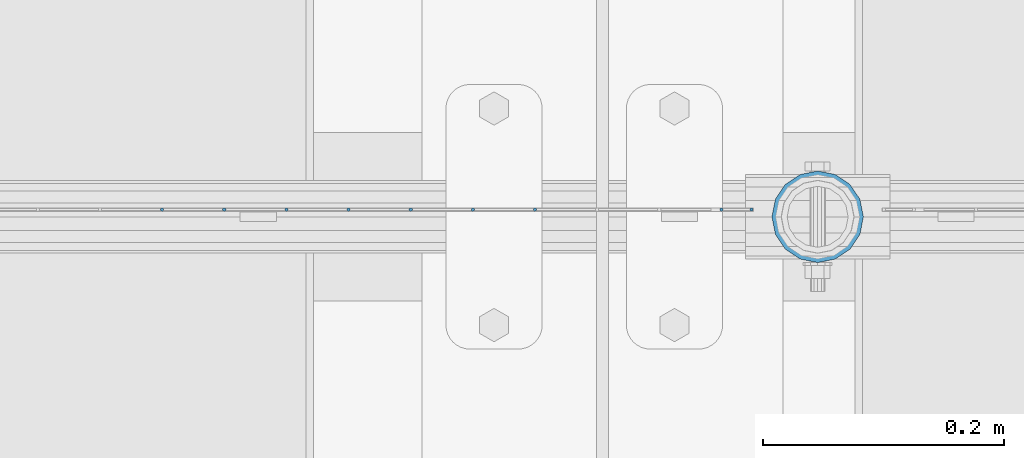
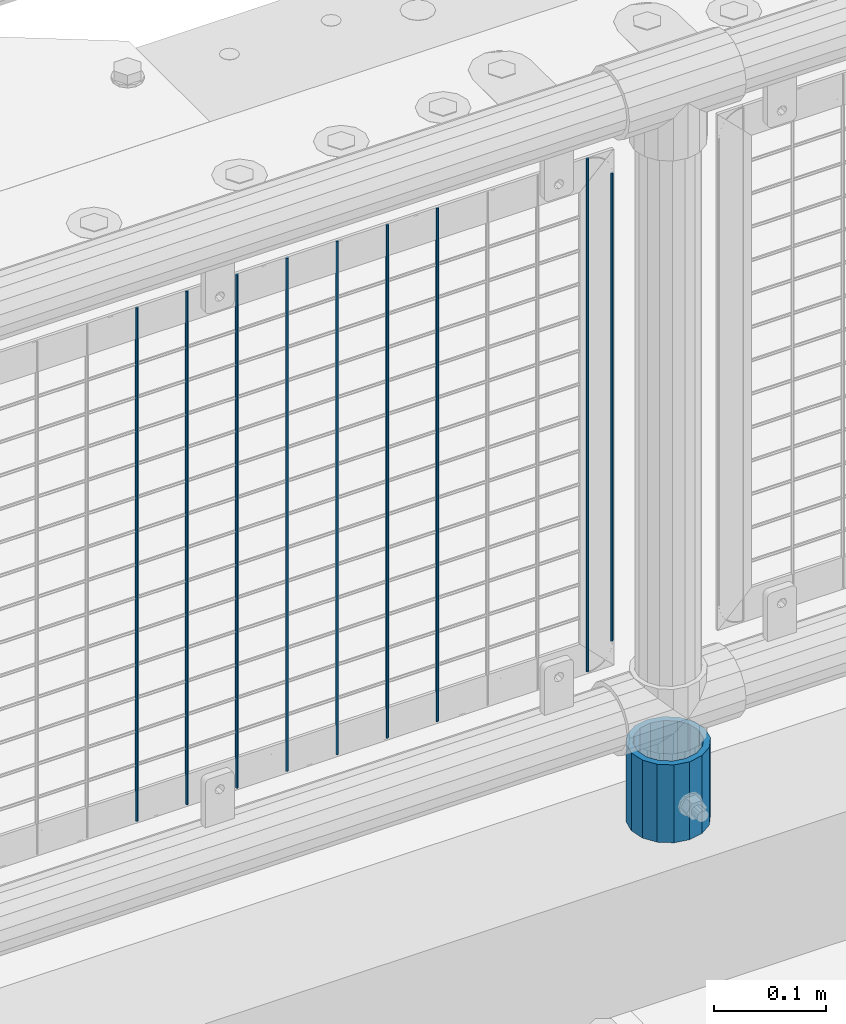
# One storey, part 91 of 240: 10 columns.
"""IFC2X3 building model written with IfcOpenShell, lengths in millimetres."""

from ifc_helpers import new_model, si_unit, frame, origin_with_axes, place, context, subcontext, project, spatial, faceted_brep, material, type_object, element, save


model = new_model("IFC2X3")

# Units and contexts
model_context = context("Model", 3, precision=1e-05, world=origin_with_axes())
body_context = subcontext(model_context, "Body", "Model", "MODEL_VIEW")
ifc_project = project(units=[si_unit("LENGTHUNIT", "METRE", prefix="MILLI"), si_unit("AREAUNIT", "SQUARE_METRE"), si_unit("VOLUMEUNIT", "CUBIC_METRE"), si_unit("MASSUNIT", "GRAM", prefix="KILO"), si_unit("TIMEUNIT", "SECOND"), si_unit("PLANEANGLEUNIT", "RADIAN"), si_unit("SOLIDANGLEUNIT", "STERADIAN"), si_unit("THERMODYNAMICTEMPERATUREUNIT", "DEGREE_CELSIUS"), si_unit("LUMINOUSINTENSITYUNIT", "LUMEN")], contexts=[model_context])

# Site, building, storey
site_placement = place(None, origin_with_axes())
site = spatial("IfcSite", under=ifc_project, at=site_placement, CompositionType="ELEMENT")
building_placement = place(site_placement, origin_with_axes())
building = spatial("IfcBuilding", under=site, at=building_placement, Name="Standard", CompositionType="ELEMENT")
storey_placement = place(building_placement, origin_with_axes())
storey = spatial("IfcBuildingStorey", under=building, at=storey_placement, Name="Undefined", CompositionType="ELEMENT", Elevation=0.0)

# Columns
ifc_material_1 = material(Name="Misc_Undefined")
column_type_1 = type_object("IfcColumnType", Name="D3", PredefinedType="NOTDEFINED")
for number, where, z_axis, x_axis in (
    (1, (52784.03, 34670.5, 353.020000000001), (-1.0, 0.0, 0.0), (0.0, 0.0, 1.0)),
    (2, (52732.375, 34670.5, 353.020000000001), (-1.0, 0.0, 0.0), (0.0, 0.0, 1.0)),
    (3, (52680.72, 34670.5, 353.020000000001), (-1.0, 0.0, 0.0), (0.0, 0.0, 1.0)),
    (4, (52629.065, 34670.5, 353.020000000001), (-1.0, 0.0, 0.0), (0.0, 0.0, 1.0)),
    (5, (52577.41, 34670.5, 353.020000000001), (-1.0, 0.0, 0.0), (0.0, 0.0, 1.0)),
    (6, (52525.755, 34670.5, 353.020000000001), (-1.0, 0.0, 0.0), (0.0, 0.0, 1.0)),
    (7, (52474.1, 34670.5, 353.020000000001), (-1.0, 0.0, 0.0), (0.0, 0.0, 1.0)),
    (8, (52938.995, 34670.5, 353.020000000001), (-1.0, 0.0, 0.0), (0.0, 0.0, 1.0)),
):
    element("IfcColumn", number, at=place(storey_placement, frame(where, z_axis=z_axis, x_axis=x_axis)), inside=storey, type_object=column_type_1, material=ifc_material_1, ObjectType="D3", context=body_context, shape_type="Brep", body=[
        faceted_brep([(-7.27595761418343e-12, -1.49999999999272, 0.0), (-7.27595761418343e-12, -0.749999999992724, -1.29903810567669), (560.0, -0.75, -1.29903810567339), (560.0, -1.5, 0.0), (0.0, 0.750000000007276, -1.29903810567669), (560.0, 0.75, -1.29903810567339), (0.0, 1.50000000000728, 0.0), (560.0, 1.5, 0.0), (0.0, 0.750000000007276, 1.29903810567669), (560.0, 0.75, 1.29903810567339), (-7.27595761418343e-12, -0.749999999992724, 1.29903810567669), (560.0, -0.75, 1.29903810567339)], [[[0, 1, 2, 3]], [[1, 4, 5, 2]], [[4, 6, 7, 5]], [[6, 8, 9, 7]], [[8, 10, 11, 9]], [[10, 0, 3, 11]], [[5, 7, 9, 11, 3, 2]], [[10, 8, 6, 4, 1, 0]]]),
    ])
column_1_placement = place(storey_placement, frame((52964.0, 34670.5, 378.020000000001), z_axis=(-1.0, 0.0, 0.0), x_axis=(0.0, 0.0, 1.0)))
element("IfcColumn", 9, at=column_1_placement, inside=storey, type_object=column_type_1, material=ifc_material_1, ObjectType="D3", context=body_context, shape_type="Brep", body=[
    faceted_brep([(-7.27595761418343e-12, -1.49999999999272, 0.0), (-7.27595761418343e-12, -0.749999999992724, -1.29903810567669), (510.0, -0.75, -1.29903810567339), (510.0, -1.5, 0.0), (0.0, 0.750000000007276, -1.29903810567669), (510.0, 0.75, -1.29903810567339), (0.0, 1.50000000000728, 0.0), (510.0, 1.5, 0.0), (0.0, 0.750000000007276, 1.29903810567669), (510.0, 0.75, 1.29903810567339), (-7.27595761418343e-12, -0.749999999992724, 1.29903810567669), (510.0, -0.75, 1.29903810567339)], [[[0, 1, 2, 3]], [[1, 4, 5, 2]], [[4, 6, 7, 5]], [[6, 8, 9, 7]], [[8, 10, 11, 9]], [[10, 0, 3, 11]], [[5, 7, 9, 11, 3, 2]], [[10, 8, 6, 4, 1, 0]]]),
])
ifc_material_2 = material()
column_type_2 = type_object("IfcColumnType", PredefinedType="NOTDEFINED")
column_2_placement = place(storey_placement, frame((53019.0, 34664.5, 168.02), z_axis=(0.0, 1.0, 0.0), x_axis=(0.0, 0.0, 1.0)))
element("IfcColumn", 10, at=column_2_placement, inside=storey, type_object=column_type_2, material=ifc_material_2, context=body_context, shape_type="Brep", body=[
    faceted_brep([(0.0, -31.75, 0.0), (0.0, -29.3331751572332, 12.1501989775934), (85.0, -29.3331751572332, 12.1501989775934), (85.0, -31.75, 0.0), (0.0, -22.4506403026753, 22.4506403026753), (85.0, -22.4506403026753, 22.4506403026753), (0.0, -12.1501989775934, 29.3331751572332), (85.0, -12.1501989775934, 29.3331751572332), (0.0, 0.0, 31.75), (85.0, 0.0, 31.75), (0.0, 12.1501989775934, 29.3331751572332), (85.0, 12.1501989775934, 29.3331751572332), (0.0, 22.4506403026753, 22.4506403026753), (85.0, 22.4506403026753, 22.4506403026753), (0.0, 29.3331751572332, 12.1501989775934), (85.0, 29.3331751572332, 12.1501989775934), (0.0, 31.75, 0.0), (85.0, 31.75, 0.0), (0.0, 29.3331751572332, -12.1501989775934), (85.0, 29.3331751572332, -12.1501989775934), (0.0, 22.4506403026753, -22.4506403026753), (85.0, 22.4506403026753, -22.4506403026753), (0.0, 12.1501989775934, -29.3331751572332), (85.0, 12.1501989775934, -29.3331751572332), (0.0, 0.0, -31.75), (85.0, 0.0, -31.75), (0.0, -12.1501989775934, -29.3331751572332), (85.0, -12.1501989775934, -29.3331751572332), (0.0, -22.4506403026753, -22.4506403026753), (85.0, -22.4506403026753, -22.4506403026753), (0.0, -29.3331751572332, -12.1501989775934), (85.0, -29.3331751572332, -12.1501989775934), (0.0, -38.0500000000029, 0.0), (0.0, -35.1536162120537, -14.5611046014892), (85.0, -35.1536162120537, -14.5611046014892), (85.0, -38.0500000000029, 0.0), (0.0, -26.9054130241493, -26.9054130241493), (85.0, -26.9054130241493, -26.9054130241493), (0.0, -14.5611046014892, -35.1536162120537), (85.0, -14.5611046014892, -35.1536162120537), (0.0, 0.0, -38.0500000000029), (85.0, 0.0, -38.0500000000029), (0.0, 14.5611046014892, -35.1536162120537), (85.0, 14.5611046014892, -35.1536162120537), (0.0, 26.9054130241493, -26.9054130241493), (85.0, 26.9054130241493, -26.9054130241493), (0.0, 35.1536162120537, -14.5611046014892), (85.0, 35.1536162120537, -14.5611046014892), (0.0, 38.0500000000029, 0.0), (85.0, 38.0500000000029, 0.0), (0.0, 35.1536162120537, 14.5611046014892), (85.0, 35.1536162120537, 14.5611046014892), (0.0, 26.9054130241493, 26.9054130241493), (85.0, 26.9054130241493, 26.9054130241493), (0.0, 14.5611046014892, 35.1536162120537), (85.0, 14.5611046014892, 35.1536162120537), (0.0, 0.0, 38.0500000000029), (85.0, 0.0, 38.0500000000029), (0.0, -14.5611046014892, 35.1536162120537), (85.0, -14.5611046014892, 35.1536162120537), (0.0, -26.9054130241493, 26.9054130241493), (85.0, -26.9054130241493, 26.9054130241493), (0.0, -35.1536162120537, 14.5611046014892), (85.0, -35.1536162120537, 14.5611046014892)], [[[0, 1, 2, 3]], [[1, 4, 5, 2]], [[4, 6, 7, 5]], [[6, 8, 9, 7]], [[8, 10, 11, 9]], [[10, 12, 13, 11]], [[12, 14, 15, 13]], [[14, 16, 17, 15]], [[16, 18, 19, 17]], [[18, 20, 21, 19]], [[20, 22, 23, 21]], [[22, 24, 25, 23]], [[24, 26, 27, 25]], [[26, 28, 29, 27]], [[28, 30, 31, 29]], [[30, 0, 3, 31]], [[32, 33, 34, 35]], [[33, 36, 37, 34]], [[36, 38, 39, 37]], [[38, 40, 41, 39]], [[40, 42, 43, 41]], [[42, 44, 45, 43]], [[44, 46, 47, 45]], [[46, 48, 49, 47]], [[48, 50, 51, 49]], [[50, 52, 53, 51]], [[52, 54, 55, 53]], [[54, 56, 57, 55]], [[56, 58, 59, 57]], [[58, 60, 61, 59]], [[60, 62, 63, 61]], [[62, 32, 35, 63]], [[37, 39, 41, 43, 45, 47, 49, 51, 53, 55, 57, 59, 61, 63, 35, 34], [5, 7, 9, 11, 13, 15, 17, 19, 21, 23, 25, 27, 29, 31, 3, 2]], [[62, 60, 58, 56, 54, 52, 50, 48, 46, 44, 42, 40, 38, 36, 33, 32], [30, 28, 26, 24, 22, 20, 18, 16, 14, 12, 10, 8, 6, 4, 1, 0]]]),
])

save(model, "model.ifc")
